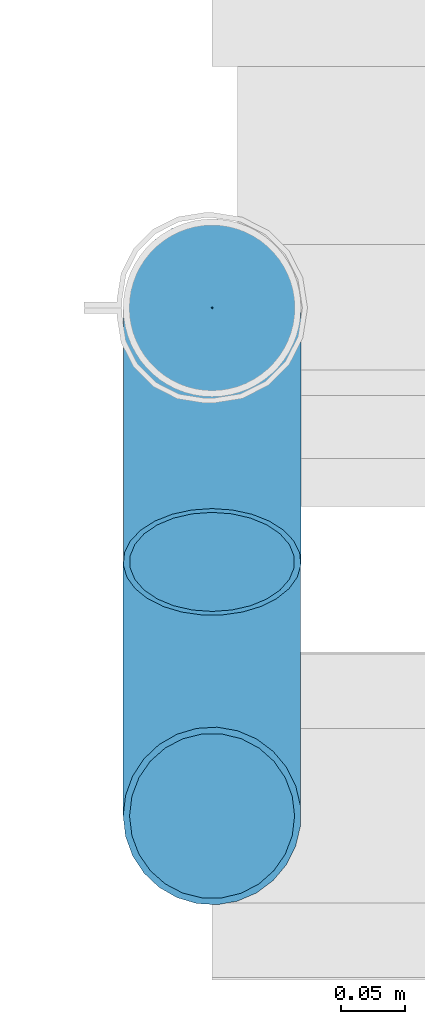
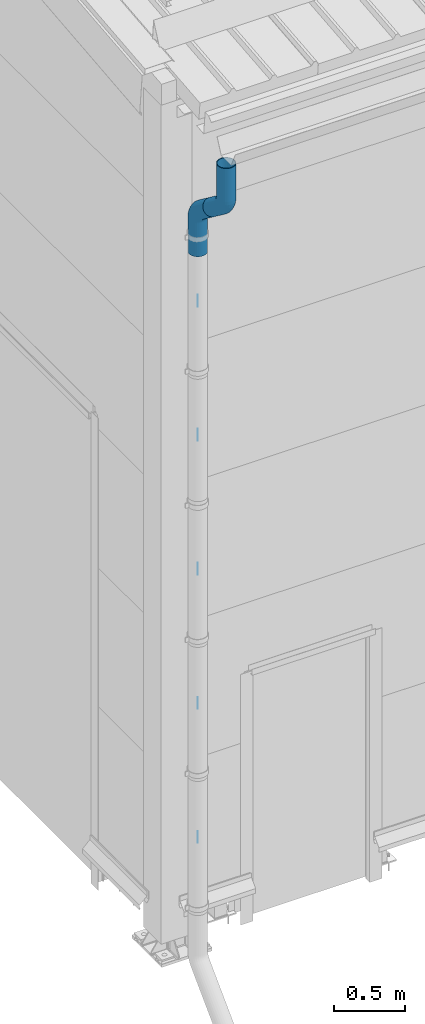
# One storey, part 83 of 709: 7 beams, 7 elements without a shape of their own.
"""IFC4 building model written with IfcOpenShell, lengths in millimetres."""

from ifc_helpers import new_model, entity, si_unit, direction, frame, origin_with_axes, place, context, subcontext, project, spatial, line, indexed_curve, outline, extrude, material, element, aggregate, save


model = new_model("IFC4")

# Units and contexts
model_context = context("Model", 3, precision=0.2, world=origin_with_axes(), true_north=direction((0.0, 1.0)))
body_context = subcontext(model_context, "Body", "Model", "MODEL_VIEW")
ifc_project = project(units=[si_unit("LENGTHUNIT", "METRE", prefix="MILLI"), si_unit("AREAUNIT", "SQUARE_METRE"), si_unit("VOLUMEUNIT", "CUBIC_METRE"), si_unit("MASSUNIT", "GRAM", prefix="KILO"), si_unit("TIMEUNIT", "SECOND"), si_unit("PLANEANGLEUNIT", "RADIAN"), si_unit("SOLIDANGLEUNIT", "STERADIAN"), si_unit("THERMODYNAMICTEMPERATUREUNIT", "DEGREE_CELSIUS"), si_unit("LUMINOUSINTENSITYUNIT", "LUMEN")], contexts=[model_context])

# Site, building, storey
site_placement = place(None, origin_with_axes())
site = spatial("IfcSite", under=ifc_project, at=site_placement, CompositionType="ELEMENT")
building_placement = place(site_placement, origin_with_axes())
building = spatial("IfcBuilding", under=site, at=building_placement, Name="Undefined", CompositionType="ELEMENT")
storey_placement = place(building_placement, origin_with_axes())
storey = spatial("IfcBuildingStorey", under=building, at=storey_placement, Name="Undefined", CompositionType="ELEMENT", Elevation=0.0)

# Assembly, beam
assembly_1_placement = place(storey_placement, frame((0.0, -820.0, 7076.92297), z_axis=(-1.0, 0.0, 0.0), x_axis=(0.0, 0.0, -1.0)))
assembly_1 = element("IfcElementAssembly", 1, at=assembly_1_placement, inside=storey)
ifc_material = material(Name="Steel_Undefined", Category="STEEL")
beam_1_placement = place(assembly_1_placement, origin_with_axes())
beam_1 = element("IfcBeam", 2, at=beam_1_placement, material=ifc_material, ObjectType="613", context=body_context, shape_type="SolidModel", body=[
    entity("IfcSweptDiskSolid", entity("IfcIndexedPolyCurve", entity("IfcCartesianPointList3D", [[0.0, 0.0, 0.0], [287.5, 0.0, 0.0], [343.4017, -13.1966, 0.0], [387.5, -50.0, 0.0], [500.0, -200.0, 0.0]]), [entity("IfcLineIndex", [1, 2]), entity("IfcArcIndex", [2, 3, 4]), entity("IfcLineIndex", [4, 5])]), 70.0, 65.0),
])
aggregate(assembly_1, [beam_1])

assembly_2_placement = place(storey_placement, frame((0.0, -620.0, 6576.92297), z_axis=(0.0, 0.6, 0.8), x_axis=(0.0, 0.8, -0.6)))
assembly_2 = element("IfcElementAssembly", 3, at=assembly_2_placement, inside=storey)
beam_2_placement = place(assembly_2_placement, origin_with_axes())
beam_2 = element("IfcBeam", 4, at=beam_2_placement, material=ifc_material, ObjectType="613", context=body_context, shape_type="SolidModel", body=[
    entity("IfcSweptDiskSolid", entity("IfcIndexedPolyCurve", entity("IfcCartesianPointList3D", [[0.0, 0.0, 0.0], [187.5, 0.0, 0.0], [243.4017, 0.0, -13.1966], [287.5, 0.0, -50.0], [460.0, 0.0, -280.0]]), [entity("IfcLineIndex", [1, 2]), entity("IfcArcIndex", [2, 3, 4]), entity("IfcLineIndex", [4, 5])]), 70.0, 65.0),
])
aggregate(assembly_2, [beam_2])

assembly_3_placement = place(storey_placement, frame((0.0, -420.0, 5701.92297), z_axis=(-1.0, 0.0, 0.0), x_axis=(0.0, 0.0, -1.0)))
assembly_3 = element("IfcElementAssembly", 5, at=assembly_3_placement, inside=storey)
beam_3_placement = place(assembly_3_placement, origin_with_axes())
beam_3 = element("IfcBeam", 6, at=beam_3_placement, material=ifc_material, ObjectType="615", context=body_context, shape_type="SolidModel", body=[
    extrude(outline(indexed_curve([(0.5, 0.0), (0.35355, 0.35355), (0.0, 0.5), (-0.35355, 0.35355), (-0.5, 0.0), (-0.35355, -0.35355), (0.0, -0.5), (0.35355, -0.35355)], segments=[line(1, 2, 3, 4, 5, 6, 7, 8, 1)])), frame((0.0, 0.0, 0.0), z_axis=(-1.0, 0.0, 0.0), x_axis=(0.0, 0.0, 1.0)), (0.0, 0.0, -1.0), 100.0),
])
aggregate(assembly_3, [beam_3])

assembly_4_placement = place(storey_placement, frame((0.0, -420.0, 4551.92297), z_axis=(-1.0, 0.0, 0.0), x_axis=(0.0, 0.0, -1.0)))
assembly_4 = element("IfcElementAssembly", 7, at=assembly_4_placement, inside=storey)
beam_4_placement = place(assembly_4_placement, origin_with_axes())
beam_4 = element("IfcBeam", 8, at=beam_4_placement, material=ifc_material, ObjectType="615", context=body_context, shape_type="SolidModel", body=[
    extrude(outline(indexed_curve([(0.5, 0.0), (0.35355, 0.35355), (0.0, 0.5), (-0.35355, 0.35355), (-0.5, 0.0), (-0.35355, -0.35355), (0.0, -0.5), (0.35355, -0.35355)], segments=[line(1, 2, 3, 4, 5, 6, 7, 8, 1)])), frame((0.0, 0.0, 0.0), z_axis=(-1.0, 0.0, 0.0), x_axis=(0.0, 0.0, 1.0)), (0.0, 0.0, -1.0), 100.0),
])
aggregate(assembly_4, [beam_4])

assembly_5_placement = place(storey_placement, frame((0.0, -420.0, 3401.92297), z_axis=(-1.0, 0.0, 0.0), x_axis=(0.0, 0.0, -1.0)))
assembly_5 = element("IfcElementAssembly", 9, at=assembly_5_placement, inside=storey)
beam_5_placement = place(assembly_5_placement, origin_with_axes())
beam_5 = element("IfcBeam", 10, at=beam_5_placement, material=ifc_material, ObjectType="615", context=body_context, shape_type="SolidModel", body=[
    extrude(outline(indexed_curve([(0.5, 0.0), (0.35355, 0.35355), (0.0, 0.5), (-0.35355, 0.35355), (-0.5, 0.0), (-0.35355, -0.35355), (0.0, -0.5), (0.35355, -0.35355)], segments=[line(1, 2, 3, 4, 5, 6, 7, 8, 1)])), frame((0.0, 0.0, 0.0), z_axis=(-1.0, 0.0, 0.0), x_axis=(0.0, 0.0, 1.0)), (0.0, 0.0, -1.0), 100.0),
])
aggregate(assembly_5, [beam_5])

assembly_6_placement = place(storey_placement, frame((0.0, -420.0, 2251.92297), z_axis=(-1.0, 0.0, 0.0), x_axis=(0.0, 0.0, -1.0)))
assembly_6 = element("IfcElementAssembly", 11, at=assembly_6_placement, inside=storey)
beam_6_placement = place(assembly_6_placement, origin_with_axes())
beam_6 = element("IfcBeam", 12, at=beam_6_placement, material=ifc_material, ObjectType="615", context=body_context, shape_type="SolidModel", body=[
    extrude(outline(indexed_curve([(0.5, 0.0), (0.35355, 0.35355), (0.0, 0.5), (-0.35355, 0.35355), (-0.5, 0.0), (-0.35355, -0.35355), (0.0, -0.5), (0.35355, -0.35355)], segments=[line(1, 2, 3, 4, 5, 6, 7, 8, 1)])), frame((0.0, 0.0, 0.0), z_axis=(-1.0, 0.0, 0.0), x_axis=(0.0, 0.0, 1.0)), (0.0, 0.0, -1.0), 100.0),
])
aggregate(assembly_6, [beam_6])

assembly_7_placement = place(storey_placement, frame((0.0, -420.0, 1101.92297), z_axis=(-1.0, 0.0, 0.0), x_axis=(0.0, 0.0, -1.0)))
assembly_7 = element("IfcElementAssembly", 13, at=assembly_7_placement, inside=storey)
beam_7_placement = place(assembly_7_placement, origin_with_axes())
beam_7 = element("IfcBeam", 14, at=beam_7_placement, material=ifc_material, ObjectType="615", context=body_context, shape_type="SolidModel", body=[
    extrude(outline(indexed_curve([(0.5, 0.0), (0.35355, 0.35355), (0.0, 0.5), (-0.35355, 0.35355), (-0.5, 0.0), (-0.35355, -0.35355), (0.0, -0.5), (0.35355, -0.35355)], segments=[line(1, 2, 3, 4, 5, 6, 7, 8, 1)])), frame((0.0, 0.0, 0.0), z_axis=(-1.0, 0.0, 0.0), x_axis=(0.0, 0.0, 1.0)), (0.0, 0.0, -1.0), 100.0),
])
aggregate(assembly_7, [beam_7])

save(model, "model.ifc")
